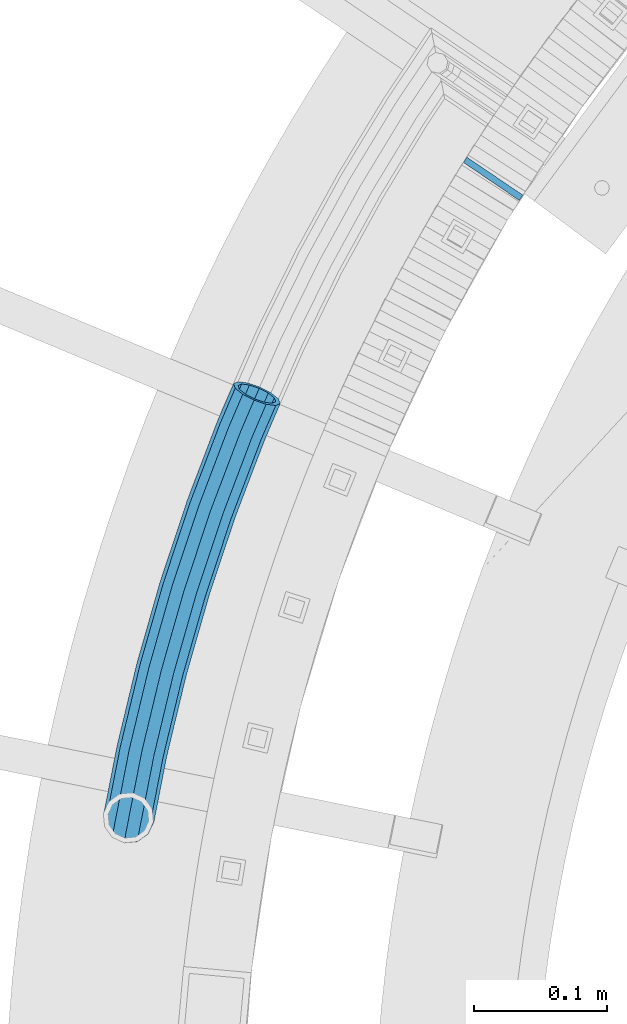
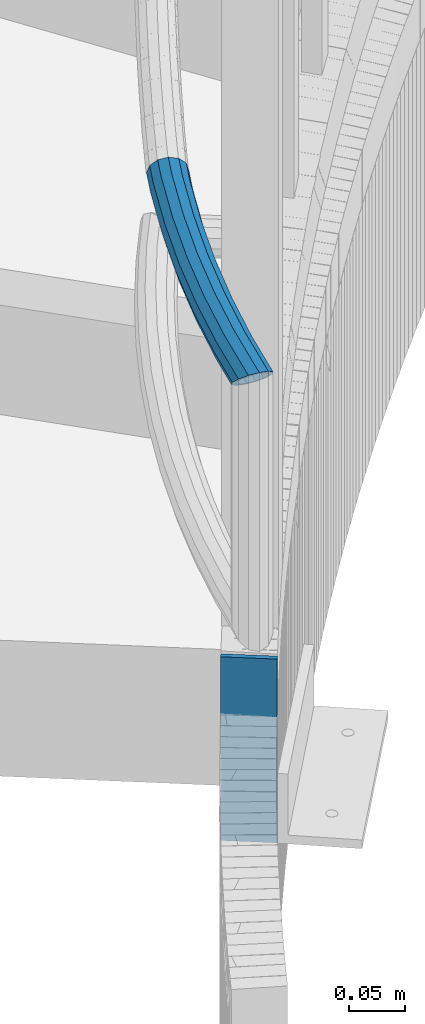
# One storey, part 478 of 975: 2 beams.
"""IFC2X3 building model written with IfcOpenShell, lengths in millimetres."""

from ifc_helpers import new_model, si_unit, frame, origin_with_axes, place, context, subcontext, project, spatial, faceted_brep, material, type_object, element, save


model = new_model("IFC2X3")

# Units and contexts
model_context = context("Model", 3, precision=1e-05, world=origin_with_axes())
body_context = subcontext(model_context, "Body", "Model", "MODEL_VIEW")
ifc_project = project(units=[si_unit("LENGTHUNIT", "METRE", prefix="MILLI"), si_unit("AREAUNIT", "SQUARE_METRE"), si_unit("VOLUMEUNIT", "CUBIC_METRE"), si_unit("MASSUNIT", "GRAM", prefix="KILO"), si_unit("TIMEUNIT", "SECOND"), si_unit("PLANEANGLEUNIT", "RADIAN"), si_unit("SOLIDANGLEUNIT", "STERADIAN"), si_unit("THERMODYNAMICTEMPERATUREUNIT", "DEGREE_CELSIUS"), si_unit("LUMINOUSINTENSITYUNIT", "LUMEN")], contexts=[model_context])

# Site, building, storey
site_placement = place(None, origin_with_axes())
site = spatial("IfcSite", under=ifc_project, at=site_placement, CompositionType="ELEMENT")
building_placement = place(site_placement, origin_with_axes())
building = spatial("IfcBuilding", under=site, at=building_placement, Name="Undefined", CompositionType="ELEMENT")
storey_placement = place(building_placement, origin_with_axes())
storey = spatial("IfcBuildingStorey", under=building, at=storey_placement, Name="Undefined", CompositionType="ELEMENT", Elevation=0.0)

# Beams
ifc_material_1 = material()
beam_type_1 = type_object("IfcBeamType", PredefinedType="NOTDEFINED")
beam_1_placement = place(storey_placement, frame((33276.7534098657, 3656.66738124268, 895.35), z_axis=(-0.927072588893235, 0.374881867956821, 0.0), x_axis=(0.374881867956822, 0.927072588893234, 0.0)))
element("IfcBeam", 1, at=beam_1_placement, inside=storey, type_object=beam_type_1, material=ifc_material_1, Name="HANDRAIL", context=body_context, shape_type="Brep", body=[
    faceted_brep([(60.0699352109168, 16.4977839420935, 21.3268679562461), (58.8905826895643, 9.52499999999998, 28.1991924198846), (121.716172446388, 9.52499999999998, 37.6114283000206), (122.602554525847, 16.4977839420935, 30.69521237566), (184.884852731708, 9.52499999999998, 44.3466152735054), (185.47666445777, 16.4977839420935, 37.3989915945785), (248.282604658447, 9.52499999999998, 48.3925963897746), (248.57877781639, 16.4977839420935, 41.4261053531336), (311.794995867323, 9.52499999999998, 49.7420686901169), (311.79499586732, 16.4977839420935, 42.7692847480284), (248.174197758721, 0.0, 50.9425090844197), (311.794995867323, 0.0, 52.2942847480263), (184.668234605711, 0.0, 46.8896220359275), (121.391734087847, 0.0, 40.1429390263911), (58.4589097067328, 0.0, 30.7146377566205), (58.8905826895643, -9.52499999999998, 28.1991924198846), (121.716172446388, -9.52499999999998, 37.6114283000206), (184.884852731708, -9.52499999999998, 44.3466152735054), (248.282604658447, -9.52499999999998, 48.3925963897746), (311.794995867323, -9.52499999999998, 49.7420686901169), (248.57877781639, -16.4977839420935, 41.4261053531336), (311.79499586732, -16.4977839420935, 42.7692847480284), (185.47666445777, -16.4977839420935, 37.3989915945785), (122.602554525847, -16.4977839420935, 30.69521237566), (60.0699352109168, -16.4977839420935, 21.3268679562461), (-2.63386027654633e-07, -19.0500000000029, 0.0), (2.00832268414888, -16.4977839420935, -9.31086811186469), (63.2919862192866, -16.4977839420935, 2.55132835548648), (61.6809607151008, -19.05, 11.9390981558681), (-2.00832268414342, -16.4977839420935, 9.31086811185378), (123.813374963847, -19.05, 21.247485724929), (186.285094309831, -19.05, 27.9083611532296), (248.983357874062, -19.05, 31.9097016218439), (311.794995867316, -19.05, 33.2442847480343), (249.387937931735, -16.4977839420935, 22.3932978905541), (311.794995867316, -16.4977839420935, 23.7192847480328), (187.093524161894, -16.4977839420935, 18.4177307118734), (125.024195401846, -16.4977839420935, 11.7997590742089), (64.4713387406337, -9.52499999999998, -4.32099610814475), (125.910577481307, -9.52499999999998, 4.88354314984826), (187.685335887956, -9.52499999999998, 11.4701070329538), (249.684111089678, -9.52499999999998, 15.4268068539131), (311.794995867314, -9.52499999999998, 16.7465008059444), (249.792517989405, 0.0, 12.876894159268), (311.794995867314, 0.0, 14.1942847480386), (187.901954013954, 0.0, 8.92710027052817), (126.235015839848, 0.0, 2.35203242347779), (64.9030117234688, 0.0, -6.83644144489153), (64.4713387406337, 9.52499999999998, -4.32099610814475), (125.910577481307, 9.52499999999998, 4.88354314984826), (187.685335887956, 9.52499999999998, 11.4701070329538), (249.684111089678, 9.52499999999998, 15.4268068539131), (311.794995867314, 9.52499999999998, 16.7465008059444), (249.387937931737, 16.4977839420935, 22.3932978905541), (311.794995867318, 16.4977839420935, 23.7192847480328), (187.093524161894, 16.4977839420935, 18.4177307118734), (125.024195401846, 16.4977839420935, 11.7997590742089), (63.2919862192866, 16.4977839420935, 2.55132835548648), (61.6809607151008, 19.05, 11.9390981558681), (123.813374963847, 19.05, 21.247485724929), (186.285094309831, 19.05, 27.9083611532296), (248.983357874062, 19.05, 31.9097016218439), (311.794995867316, 19.05, 33.2442847480343), (348.368869141113, 19.05, 32.4671855399574), (347.485147443735, 16.4977839420935, 22.960962316105), (345.402750816893, 9.52499999999998, 16.0324238592402), (342.679655755073, 0.0, 13.5380664536096), (340.045513381006, -9.52499999999998, 16.1462511516875), (338.206140016566, -16.4977839420935, 23.1581169699057), (337.654394269339, -19.05, 32.694840124841), (338.538115966719, -16.4977839420935, 42.2010633486934), (340.620512593559, -9.52499999999998, 49.1296018055618), (343.343607655379, 0.0, 51.6239592111924), (345.977750029448, 9.52499999999998, 49.0157745131182), (347.817123393887, 16.4977839420935, 42.0039086948964), (30.8300686874172, 19.05, 5.96753377287678), (26.3555085711123, 16.4977839420935, 14.8010317135013), (18.0679540281853, 9.52499999999998, 20.2974774511349), (8.18804860563978, 0.0, 20.9841027891343), (-0.636895017260031, -9.52499999999998, 16.6769270226869), (-2.87089389720495, -12.4068124715823, 13.3098702967654), (-6.00615594448391, -16.4977839420935, 8.35924424300174), (-6.52077301064855, -19.05, -1.55217159801396), (-2.06827399082977, -16.4977839420935, -10.2812404227989), (2.89539406197036, -12.2906139785937, -13.4234565270126), (6.182485255762, -9.52499999999998, -15.6035107622774), (16.0623906783076, 0.0, -16.2901361002805), (24.8873343012056, 9.52499999999998, -11.982960333833), (30.2926796074462, 16.4977839420935, -3.83608773120432), (-1.62004696520853, -13.3082123799554, 7.51076694355652), (-2.5217261879443, -13.3082123799554, 7.29613581351077), (-1.814592983088, -12.385526581035, 8.41270980785703), (1.62004696521399, -13.3082123799554, -7.51076694356743), (1.83007869195353, -12.3120815226064, -8.48450374513777), (0.654831921336154, -13.3082123799554, -7.74052181689694), (-2.1246523829177e-07, -15.367000000002, 0.0), (-2.93685062131772, -15.367, -0.699072964907828), (60.3814001417268, -13.3082123799554, 19.5118991281706), (61.6809607151008, -15.367, 11.9390981558681), (62.980521288473, -13.3082123799554, 4.36629718356198), (63.9318656556989, -7.68349999999998, -1.17737788377053), (7.33141390376477, -7.68349999999998, -12.1330819016548), (64.2800818618489, 0.0, -3.20650378874416), (15.3012042779483, 0.0, -12.6869596743018), (63.9318656556989, 7.68349999999998, -1.17737788377053), (22.4199921337531, 7.68349999999998, -9.21250455603149), (62.980521288473, 13.3082123799554, 4.36629718356198), (26.7803040141243, 13.3082123799554, -2.64069398992069), (61.6809607151008, 15.367, 11.9390981558681), (27.2137978719638, 15.367, 5.26756069004477), (59.0818395683509, 0.0, 27.0847001004731), (59.4300557745028, -7.68349999999998, 25.0555741955031), (1.83044715019423, -7.68349999999998, 13.906471244889), (8.94923500599725, 0.0, 17.3809263631592), (59.4300557745028, 7.68349999999998, 25.0555741955031), (16.9190253801826, 7.68349999999998, 16.8270485905086), (60.3814001417268, 13.3082123799554, 19.5118991281706), (23.6043193781461, 13.3082123799554, 12.3932490288134), (122.121631599764, -7.68349999999998, 34.4477327355016), (122.836646477193, -13.3082123799554, 28.8686518898576), (123.813374963847, -15.367, 21.247485724929), (124.790103450501, -13.3082123799554, 13.626319560015), (125.50511832793, -7.68349999999998, 8.04723871436727), (125.766831937157, 0.0, 6.00515339509002), (125.50511832793, 7.68349999999998, 8.04723871436727), (124.790103450501, 13.3082123799554, 13.626319560015), (123.813374963847, 15.367, 21.247485724929), (122.836646477193, 13.3082123799554, 28.8686518898576), (122.121631599764, 7.68349999999998, 34.4477327355016), (121.859917990541, 0.0, 36.4898180547752), (184.980827481841, 0.0, 43.2199115986041), (185.155566103478, -7.68349999999998, 41.1685528102498), (185.632960895837, -13.3082123799554, 35.5641363759169), (186.285094309831, -15.367, 27.9083611532296), (186.937227723827, -13.3082123799554, 20.2525859305424), (187.414622516184, -7.68349999999998, 14.6481694962058), (187.589361137821, 0.0, 12.5968107078552), (187.414622516184, 7.68349999999998, 14.6481694962058), (186.937227723827, 13.3082123799554, 20.2525859305424), (186.285094309831, 15.367, 27.9083611532296), (185.632960895837, 13.3082123799554, 35.5641363759169), (185.155566103478, 7.68349999999998, 41.1685528102498), (248.418083613467, 7.68349999999998, 45.2059034013073), (248.33063538102, 0.0, 47.2628329749932), (248.418083613467, -7.68349999999998, 45.2059034013073), (248.656996627542, -13.3082123799554, 39.5862672984149), (248.983357874062, -15.367, 31.9097016218439), (249.309719120583, -13.3082123799554, 24.2331359452764), (249.548632134658, -7.68349999999998, 18.613499842384), (249.636080367107, 0.0, 16.5565702686981), (249.548632134658, 7.68349999999998, 18.613499842384), (249.309719120583, 13.3082123799554, 24.2331359452764), (248.983357874062, 15.367, 31.9097016218439), (248.656996627542, 13.3082123799554, 39.5862672984149), (311.79499586732, 13.3082123799554, 40.9277847480298), (311.794995867323, 7.68349999999998, 46.552497127981), (311.794995867323, 0.0, 48.6112847480254), (311.794995867323, -7.68349999999998, 46.552497127981), (311.79499586732, -13.3082123799554, 40.9277847480298), (311.794995867316, -15.367, 33.2442847480343), (311.794995867318, -13.3082123799554, 25.5607847480314), (311.794995867316, -7.68349999999998, 19.9360723680838), (311.794995867316, 0.0, 17.8772847480395), (311.794995867316, 7.68349999999998, 19.9360723680838), (311.794995867318, 13.3082123799554, 25.5607847480314), (311.794995867316, 15.367, 33.2442847480343), (347.333136570174, 15.367, 32.4891921498274), (346.888061667412, 13.3082123799554, 40.1821488281457), (345.404300486765, 7.68349999999998, 45.8383872548438), (343.279425638351, 0.0, 47.9423229112872), (341.082795621816, -7.68349999999998, 45.9302079374138), (339.402995676166, -13.3082123799554, 40.3411869155389), (338.690126840276, -15.367, 32.672833514971), (339.135201743044, -13.3082123799554, 24.9798768366491), (340.618962923687, -7.68349999999998, 19.3236384099582), (342.743837772105, 0.0, 17.2197027535076), (344.940467788638, 7.68349999999998, 19.2318177273846), (346.62026773429, 13.3082123799554, 24.8208387492559)], [[[0, 1, 2, 3]], [[3, 2, 4, 5]], [[5, 4, 6, 7]], [[7, 6, 8, 9]], [[6, 10, 11, 8]], [[4, 12, 10, 6]], [[2, 13, 12, 4]], [[1, 14, 13, 2]], [[14, 15, 16, 13]], [[13, 16, 17, 12]], [[12, 17, 18, 10]], [[10, 18, 19, 11]], [[18, 20, 21, 19]], [[17, 22, 20, 18]], [[16, 23, 22, 17]], [[15, 24, 23, 16]], [[25, 26, 27, 28]], [[29, 25, 28, 24]], [[24, 28, 30, 23]], [[23, 30, 31, 22]], [[22, 31, 32, 20]], [[20, 32, 33, 21]], [[32, 34, 35, 33]], [[31, 36, 34, 32]], [[30, 37, 36, 31]], [[28, 27, 37, 30]], [[27, 38, 39, 37]], [[37, 39, 40, 36]], [[36, 40, 41, 34]], [[34, 41, 42, 35]], [[41, 43, 44, 42]], [[40, 45, 43, 41]], [[39, 46, 45, 40]], [[38, 47, 46, 39]], [[47, 48, 49, 46]], [[46, 49, 50, 45]], [[45, 50, 51, 43]], [[43, 51, 52, 44]], [[51, 53, 54, 52]], [[50, 55, 53, 51]], [[49, 56, 55, 50]], [[48, 57, 56, 49]], [[57, 58, 59, 56]], [[56, 59, 60, 55]], [[55, 60, 61, 53]], [[53, 61, 62, 54]], [[54, 62, 63, 64]], [[52, 54, 64, 65]], [[44, 52, 65, 66]], [[42, 44, 66, 67]], [[35, 42, 67, 68]], [[33, 35, 68, 69]], [[21, 33, 69, 70]], [[19, 21, 70, 71]], [[11, 19, 71, 72]], [[8, 11, 72, 73]], [[9, 8, 73, 74]], [[62, 9, 74, 63]], [[61, 7, 9, 62]], [[60, 5, 7, 61]], [[59, 3, 5, 60]], [[58, 0, 3, 59]], [[0, 58, 75, 76]], [[1, 0, 76, 77]], [[14, 1, 77, 78]], [[15, 14, 78, 79]], [[29, 24, 15, 79, 80]], [[29, 80, 81]], [[25, 29, 81, 82]], [[26, 25, 82, 83]], [[26, 83, 84]], [[38, 27, 26, 84, 85]], [[47, 38, 85, 86]], [[48, 47, 86, 87]], [[57, 48, 87, 88]], [[58, 57, 88, 75]], [[89, 90, 91]], [[92, 93, 94]], [[95, 92, 94, 96]], [[89, 95, 96, 90]], [[95, 89, 97, 98]], [[92, 95, 98, 99]], [[92, 99, 100, 101, 93]], [[100, 102, 103, 101]], [[102, 104, 105, 103]], [[104, 106, 107, 105]], [[106, 108, 109, 107]], [[110, 111, 112, 113]], [[114, 110, 113, 115]], [[116, 114, 115, 117]], [[108, 116, 117, 109]], [[87, 86, 85, 84, 83, 82, 81, 80, 79, 78, 77, 76, 75, 88], [115, 113, 112, 91, 90, 96, 94, 93, 101, 103, 105, 107, 109, 117]], [[111, 97, 89, 91, 112]], [[97, 111, 118, 119]], [[98, 97, 119, 120]], [[99, 98, 120, 121]], [[100, 99, 121, 122]], [[102, 100, 122, 123]], [[104, 102, 123, 124]], [[106, 104, 124, 125]], [[108, 106, 125, 126]], [[116, 108, 126, 127]], [[114, 116, 127, 128]], [[110, 114, 128, 129]], [[111, 110, 129, 118]], [[118, 129, 130, 131]], [[119, 118, 131, 132]], [[120, 119, 132, 133]], [[121, 120, 133, 134]], [[122, 121, 134, 135]], [[123, 122, 135, 136]], [[124, 123, 136, 137]], [[125, 124, 137, 138]], [[126, 125, 138, 139]], [[127, 126, 139, 140]], [[128, 127, 140, 141]], [[129, 128, 141, 130]], [[130, 141, 142, 143]], [[131, 130, 143, 144]], [[132, 131, 144, 145]], [[133, 132, 145, 146]], [[134, 133, 146, 147]], [[135, 134, 147, 148]], [[136, 135, 148, 149]], [[137, 136, 149, 150]], [[138, 137, 150, 151]], [[139, 138, 151, 152]], [[140, 139, 152, 153]], [[141, 140, 153, 142]], [[142, 153, 154, 155]], [[143, 142, 155, 156]], [[144, 143, 156, 157]], [[145, 144, 157, 158]], [[146, 145, 158, 159]], [[147, 146, 159, 160]], [[148, 147, 160, 161]], [[149, 148, 161, 162]], [[150, 149, 162, 163]], [[151, 150, 163, 164]], [[152, 151, 164, 165]], [[153, 152, 165, 154]], [[154, 165, 166, 167]], [[155, 154, 167, 168]], [[156, 155, 168, 169]], [[157, 156, 169, 170]], [[158, 157, 170, 171]], [[159, 158, 171, 172]], [[160, 159, 172, 173]], [[161, 160, 173, 174]], [[162, 161, 174, 175]], [[163, 162, 175, 176]], [[164, 163, 176, 177]], [[165, 164, 177, 166]], [[73, 72, 71, 70, 69, 68, 67, 66, 65, 64, 63, 74], [176, 175, 174, 173, 172, 171, 170, 169, 168, 167, 166, 177]]]),
])
ifc_material_2 = material(Name="STEEL/A36")
beam_type_2 = type_object("IfcBeamType", PredefinedType="NOTDEFINED")
beam_2_placement = place(storey_placement, frame((33552.2493713252, 4147.91858109338, 205.470012041039), z_axis=(0.827279193066025, -0.56179100804483, 0.0), x_axis=(0.0, 0.0, -1.0)))
element("IfcBeam", 2, at=beam_2_placement, inside=storey, type_object=beam_type_2, material=ifc_material_2, Name="PLATE", context=body_context, shape_type="Brep", body=[
    faceted_brep([(0.0, -2.3809999999612, -25.3999999999396), (0.0, -2.38100000002669, 25.3999999999396), (0.0, 2.38099999996848, 25.399999999936), (0.0, 2.38100000003396, -25.3999999999432), (200.70735930295, -2.38100000002669, 25.3999999999396), (200.707320630748, 2.38099999996848, 25.399999999936), (200.707320630748, 2.38100000003396, -25.3999999999432), (200.70735930295, -2.3809999999612, -25.3999999999396)], [[[0, 1, 2, 3]], [[2, 1, 4, 5]], [[3, 2, 5, 6]], [[0, 3, 6, 7]], [[1, 0, 7, 4]], [[6, 5, 4, 7]]]),
])

save(model, "model.ifc")
